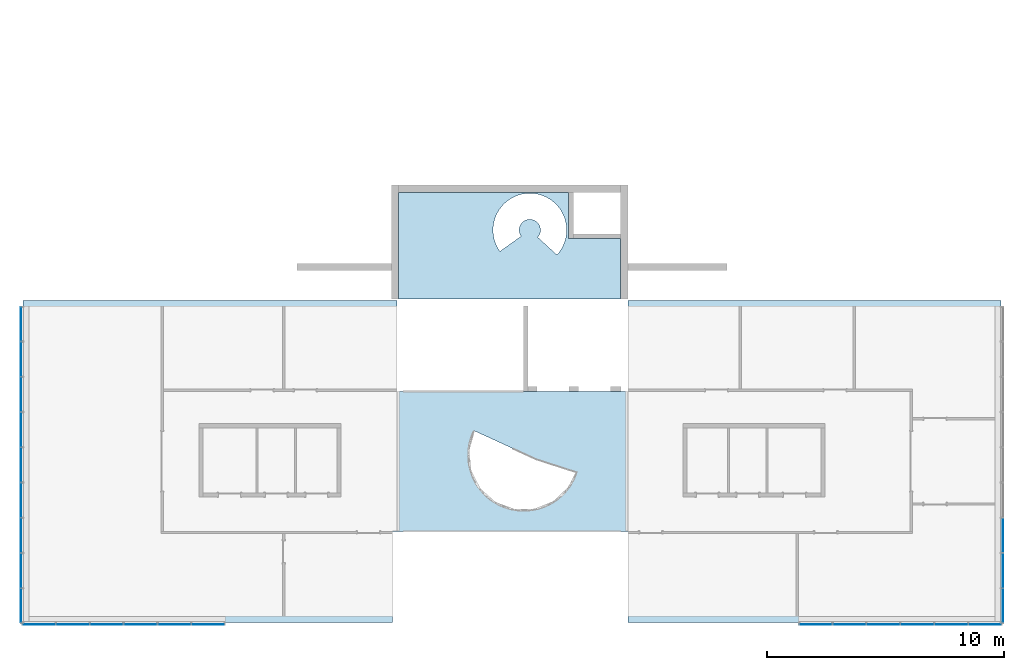
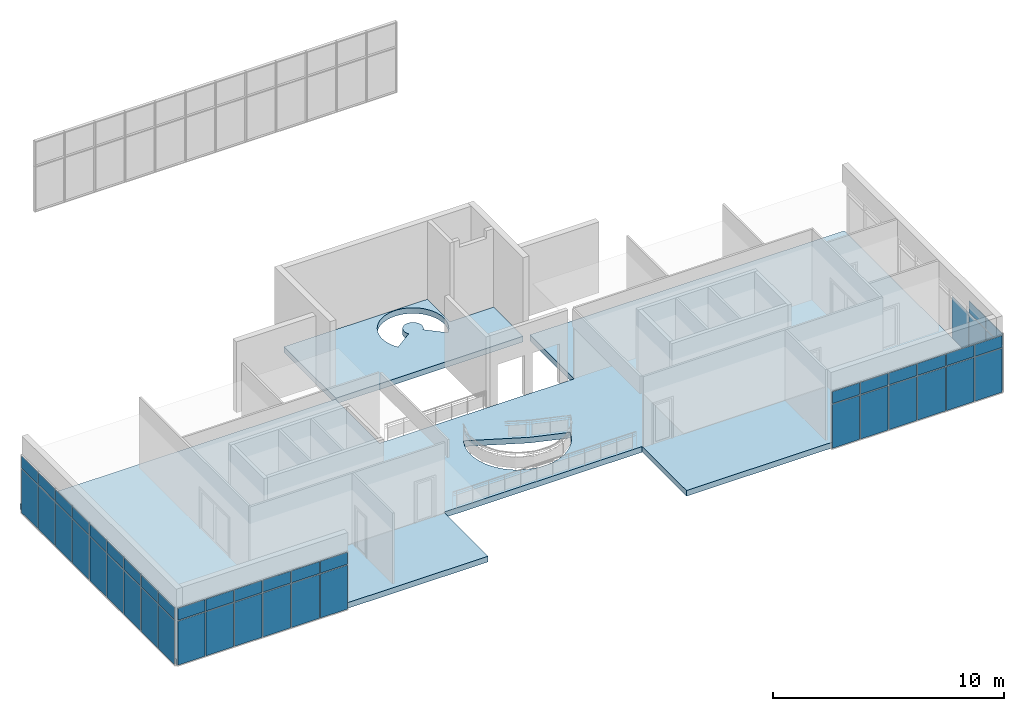
# One storey, part 6 of 11: 47 plates, 2 slabs, 2 openings, 4 elements without a shape of their own.
"""IFC2X3 building model written with IfcOpenShell, lengths in millimetres."""

from ifc_helpers import new_model, entity, si_unit, converted_unit, direction, frame, frame_2d, origin, origin_2d_with_axis, place, context, subcontext, project, spatial, polyline, circle_curve, parameter, trimmed, segment, composite_curve, rectangle, outline, extrude, source, transform, mapped, material, layer, layer_set, layer_usage, type_object, type_shapes, element, aggregate, save


model = new_model("IFC2X3")

# Units and contexts
model_context = context("Model", 3, precision=1e-06, world=origin(), true_north=direction((2.0, 6.12303176911189e-17, 1.0)))
context_of_model = context(None, 3, precision=1e-06, world=origin(), true_north=direction((2.0, 6.12303176911189e-17, 1.0)))
body_context = subcontext(model_context, "Body", "Model", "MODEL_VIEW")
ifc_project = project(units=[si_unit("LENGTHUNIT", "METRE", prefix="MILLI"), si_unit("AREAUNIT", "SQUARE_METRE", prefix="MILLI"), si_unit("VOLUMEUNIT", "CUBIC_METRE", prefix="MILLI"), converted_unit("PLANEANGLEUNIT", "DEGREE", entity("IfcRatioMeasure", 0.0174532925199433), si_unit("PLANEANGLEUNIT", "RADIAN"), dimensions=[0, 0, 0, 0, 0, 0, 0]), si_unit("TIMEUNIT", "SECOND")], contexts=[model_context, context_of_model])

# Site, building, storey
site_placement = place(None, origin())
site = spatial("IfcSite", under=ifc_project, at=site_placement, CompositionType="ELEMENT")
building_placement = place(site_placement, origin())
building = spatial("IfcBuilding", under=site, at=building_placement, CompositionType="ELEMENT")
storey_placement = place(building_placement, frame((0.0, 0.0, 3750.0)))
storey = spatial("IfcBuildingStorey", under=building, at=storey_placement, Name="02. 2 etg.", CompositionType="ELEMENT", Elevation=3750.00000000068)

# Curtain wall, plates
curtain_wall_1_placement = place(storey_placement, origin())
curtain_wall_1 = element("IfcCurtainWall", 1, at=curtain_wall_1_placement, inside=storey, Name="Curtain Wall:Storefront", ObjectType="Curtain Wall:Storefront")
ifc_material_1 = material(Name="Glass")
plate_type_1 = type_object("IfcPlateType", Name="Glazed", PredefinedType="CURTAIN_PANEL")
shared_shape_1 = source(origin(), body_context, "Body", "SweptSolid", [
    extrude(rectangle(XDim=25.0, YDim=1436.66666666667, at=origin_2d_with_axis()), frame((0.0, 37.0, 0.0), z_axis=(0.0, 0.0, 1.0), x_axis=(0.0, 1.0, 0.0)), (0.0, 0.0, 1.0), 2325.0),
])
type_shapes(plate_type_1, [shared_shape_1])
placement = place(building_placement, origin())
plate_1_placement = place(placement, frame((41098.2357123495, -9723.33333333333, 3500.0), z_axis=(0.0, 0.0, 1.0), x_axis=(0.0, -1.0, 0.0)))
plate_1 = element("IfcPlate", 2, at=plate_1_placement, type_object=plate_type_1, material=ifc_material_1, Name="Curtain Wall:Storefront", ObjectType="Glazed", context=body_context, shape_type="MappedRepresentation", body=[
    mapped(shared_shape_1, transform((0.0, 0.0, 0.0), scale=1.0)),
])
plate_2_placement = place(placement, frame((41098.2357123495, -11210.0, 3500.0), z_axis=(0.0, 0.0, 1.0), x_axis=(0.0, -1.0, 0.0)))
plate_2 = element("IfcPlate", 3, at=plate_2_placement, type_object=plate_type_1, material=ifc_material_1, Name="Curtain Wall:Storefront", ObjectType="Glazed", context=body_context, shape_type="MappedRepresentation", body=[
    mapped(shared_shape_1, transform((0.0, 0.0, 0.0), scale=1.0)),
])

curtain_wall_2_placement = place(storey_placement, origin())
curtain_wall_2 = element("IfcCurtainWall", 4, at=curtain_wall_2_placement, inside=storey, Name="Curtain Wall:Storefront", ObjectType="Curtain Wall:Storefront")
plate_type_2 = type_object("IfcPlateType", Name="Glazed", PredefinedType="CURTAIN_PANEL")
shared_shape_2 = source(origin(), body_context, "Body", "SweptSolid", [
    extrude(rectangle(XDim=25.0, YDim=1411.66666666667, at=frame_2d((0.0, 1.13686837721616e-13), x_axis=(1.0, 0.0))), frame((0.0, -37.0, 0.0), z_axis=(0.0, 0.0, 1.0), x_axis=(0.0, 1.0, 0.0)), (0.0, 0.0, 1.0), 2325.0),
])
type_shapes(plate_type_2, [shared_shape_2])
plate_3_placement = place(placement, frame((-240.0, -815.833333333277, 3500.0), z_axis=(0.0, 0.0, 1.0), x_axis=(0.0, -1.0, 0.0)))
plate_3 = element("IfcPlate", 5, at=plate_3_placement, type_object=plate_type_2, material=ifc_material_1, Name="Curtain Wall:Storefront", ObjectType="Glazed", context=body_context, shape_type="MappedRepresentation", body=[
    mapped(shared_shape_2, transform((0.0, 0.0, 0.0), scale=1.0)),
])
plate_4_placement = place(placement, frame((-240.0, -12684.1666666667, 3500.0), z_axis=(0.0, 0.0, 1.0), x_axis=(0.0, -1.0, 0.0)))
plate_4 = element("IfcPlate", 6, at=plate_4_placement, type_object=plate_type_2, material=ifc_material_1, Name="Curtain Wall:Storefront", ObjectType="Glazed", context=body_context, shape_type="MappedRepresentation", body=[
    mapped(shared_shape_2, transform((0.0, 0.0, 0.0), scale=1.0)),
])
plate_type_3 = type_object("IfcPlateType", Name="Glazed", PredefinedType="CURTAIN_PANEL")
shared_shape_3 = source(origin(), body_context, "Body", "SweptSolid", [
    extrude(rectangle(XDim=25.0, YDim=1436.66666666667, at=origin_2d_with_axis()), frame((0.0, -37.0, 0.0), z_axis=(0.0, 0.0, 1.0), x_axis=(0.0, 1.0, 0.0)), (0.0, 0.0, 1.0), 2325.0),
])
type_shapes(plate_type_3, [shared_shape_3])
plate_5_placement = place(placement, frame((-240.0, -2290.0, 3500.0), z_axis=(0.0, 0.0, 1.0), x_axis=(0.0, -1.0, 0.0)))
plate_5 = element("IfcPlate", 7, at=plate_5_placement, type_object=plate_type_3, material=ifc_material_1, Name="Curtain Wall:Storefront", ObjectType="Glazed", context=body_context, shape_type="MappedRepresentation", body=[
    mapped(shared_shape_3, transform((0.0, 0.0, 0.0), scale=1.0)),
])
plate_6_placement = place(placement, frame((-240.0, -3776.66666666662, 3500.0), z_axis=(0.0, 0.0, 1.0), x_axis=(0.0, -1.0, 0.0)))
plate_6 = element("IfcPlate", 8, at=plate_6_placement, type_object=plate_type_3, material=ifc_material_1, Name="Curtain Wall:Storefront", ObjectType="Glazed", context=body_context, shape_type="MappedRepresentation", body=[
    mapped(shared_shape_3, transform((0.0, 0.0, 0.0), scale=1.0)),
])
plate_7_placement = place(placement, frame((-240.0, -5263.3333333333, 3500.0), z_axis=(0.0, 0.0, 1.0), x_axis=(0.0, -1.0, 0.0)))
plate_7 = element("IfcPlate", 9, at=plate_7_placement, type_object=plate_type_3, material=ifc_material_1, Name="Curtain Wall:Storefront", ObjectType="Glazed", context=body_context, shape_type="MappedRepresentation", body=[
    mapped(shared_shape_3, transform((0.0, 0.0, 0.0), scale=1.0)),
])
plate_8_placement = place(placement, frame((-240.0, -6750.0, 3500.0), z_axis=(0.0, 0.0, 1.0), x_axis=(0.0, -1.0, 0.0)))
plate_8 = element("IfcPlate", 10, at=plate_8_placement, type_object=plate_type_3, material=ifc_material_1, Name="Curtain Wall:Storefront", ObjectType="Glazed", context=body_context, shape_type="MappedRepresentation", body=[
    mapped(shared_shape_3, transform((0.0, 0.0, 0.0), scale=1.0)),
])
plate_9_placement = place(placement, frame((-240.0, -8236.66666666664, 3500.0), z_axis=(0.0, 0.0, 1.0), x_axis=(0.0, -1.0, 0.0)))
plate_9 = element("IfcPlate", 11, at=plate_9_placement, type_object=plate_type_3, material=ifc_material_1, Name="Curtain Wall:Storefront", ObjectType="Glazed", context=body_context, shape_type="MappedRepresentation", body=[
    mapped(shared_shape_3, transform((0.0, 0.0, 0.0), scale=1.0)),
])
plate_10_placement = place(placement, frame((-240.0, -9723.33333333331, 3500.0), z_axis=(0.0, 0.0, 1.0), x_axis=(0.0, -1.0, 0.0)))
plate_10 = element("IfcPlate", 12, at=plate_10_placement, type_object=plate_type_3, material=ifc_material_1, Name="Curtain Wall:Storefront", ObjectType="Glazed", context=body_context, shape_type="MappedRepresentation", body=[
    mapped(shared_shape_3, transform((0.0, 0.0, 0.0), scale=1.0)),
])
plate_11_placement = place(placement, frame((-240.0, -11210.0, 3500.0), z_axis=(0.0, 0.0, 1.0), x_axis=(0.0, -1.0, 0.0)))
plate_11 = element("IfcPlate", 13, at=plate_11_placement, type_object=plate_type_3, material=ifc_material_1, Name="Curtain Wall:Storefront", ObjectType="Glazed", context=body_context, shape_type="MappedRepresentation", body=[
    mapped(shared_shape_3, transform((0.0, 0.0, 0.0), scale=1.0)),
])
plate_type_4 = type_object("IfcPlateType", Name="Glazed", PredefinedType="CURTAIN_PANEL")
shared_shape_4 = source(origin(), body_context, "Body", "SweptSolid", [
    extrude(rectangle(XDim=25.0, YDim=1411.66666666667, at=frame_2d((0.0, 5.6843418860808e-14), x_axis=(1.0, 0.0))), frame((0.0, -37.0, 0.0), z_axis=(0.0, 0.0, 1.0), x_axis=(0.0, 1.0, 0.0)), (0.0, 0.0, 1.0), 625.000000000002),
])
type_shapes(plate_type_4, [shared_shape_4])
plate_12_placement = place(storey_placement, frame((-240.0, -815.833333333278, 2125.0), z_axis=(0.0, 0.0, 1.0), x_axis=(0.0, -1.0, 0.0)))
plate_12 = element("IfcPlate", 14, at=plate_12_placement, type_object=plate_type_4, material=ifc_material_1, Name="Curtain Wall:Storefront", ObjectType="Glazed", context=body_context, shape_type="MappedRepresentation", body=[
    mapped(shared_shape_4, transform((0.0, 0.0, 0.0), scale=1.0)),
])
plate_13_placement = place(storey_placement, frame((-240.0, -12684.1666666667, 2125.0), z_axis=(0.0, 0.0, 1.0), x_axis=(0.0, -1.0, 0.0)))
plate_13 = element("IfcPlate", 15, at=plate_13_placement, type_object=plate_type_4, material=ifc_material_1, Name="Curtain Wall:Storefront", ObjectType="Glazed", context=body_context, shape_type="MappedRepresentation", body=[
    mapped(shared_shape_4, transform((0.0, 0.0, 0.0), scale=1.0)),
])
plate_type_5 = type_object("IfcPlateType", Name="Glazed", PredefinedType="CURTAIN_PANEL")
shared_shape_5 = source(origin(), body_context, "Body", "SweptSolid", [
    extrude(rectangle(XDim=25.0, YDim=1436.66666666667, at=origin_2d_with_axis()), frame((0.0, -37.0, 0.0), z_axis=(0.0, 0.0, 1.0), x_axis=(0.0, 1.0, 0.0)), (0.0, 0.0, 1.0), 625.000000000002),
])
type_shapes(plate_type_5, [shared_shape_5])
plate_14_placement = place(storey_placement, frame((-240.0, -2290.0, 2125.0), z_axis=(0.0, 0.0, 1.0), x_axis=(0.0, -1.0, 0.0)))
plate_14 = element("IfcPlate", 16, at=plate_14_placement, type_object=plate_type_5, material=ifc_material_1, Name="Curtain Wall:Storefront", ObjectType="Glazed", context=body_context, shape_type="MappedRepresentation", body=[
    mapped(shared_shape_5, transform((0.0, 0.0, 0.0), scale=1.0)),
])
plate_15_placement = place(storey_placement, frame((-240.0, -3776.66666666662, 2125.0), z_axis=(0.0, 0.0, 1.0), x_axis=(0.0, -1.0, 0.0)))
plate_15 = element("IfcPlate", 17, at=plate_15_placement, type_object=plate_type_5, material=ifc_material_1, Name="Curtain Wall:Storefront", ObjectType="Glazed", context=body_context, shape_type="MappedRepresentation", body=[
    mapped(shared_shape_5, transform((0.0, 0.0, 0.0), scale=1.0)),
])
plate_16_placement = place(storey_placement, frame((-240.0, -5263.3333333333, 2125.0), z_axis=(0.0, 0.0, 1.0), x_axis=(0.0, -1.0, 0.0)))
plate_16 = element("IfcPlate", 18, at=plate_16_placement, type_object=plate_type_5, material=ifc_material_1, Name="Curtain Wall:Storefront", ObjectType="Glazed", context=body_context, shape_type="MappedRepresentation", body=[
    mapped(shared_shape_5, transform((0.0, 0.0, 0.0), scale=1.0)),
])
plate_17_placement = place(storey_placement, frame((-240.0, -6750.0, 2125.0), z_axis=(0.0, 0.0, 1.0), x_axis=(0.0, -1.0, 0.0)))
plate_17 = element("IfcPlate", 19, at=plate_17_placement, type_object=plate_type_5, material=ifc_material_1, Name="Curtain Wall:Storefront", ObjectType="Glazed", context=body_context, shape_type="MappedRepresentation", body=[
    mapped(shared_shape_5, transform((0.0, 0.0, 0.0), scale=1.0)),
])
plate_18_placement = place(storey_placement, frame((-240.0, -8236.66666666664, 2125.0), z_axis=(0.0, 0.0, 1.0), x_axis=(0.0, -1.0, 0.0)))
plate_18 = element("IfcPlate", 20, at=plate_18_placement, type_object=plate_type_5, material=ifc_material_1, Name="Curtain Wall:Storefront", ObjectType="Glazed", context=body_context, shape_type="MappedRepresentation", body=[
    mapped(shared_shape_5, transform((0.0, 0.0, 0.0), scale=1.0)),
])
plate_19_placement = place(storey_placement, frame((-240.0, -9723.33333333331, 2125.0), z_axis=(0.0, 0.0, 1.0), x_axis=(0.0, -1.0, 0.0)))
plate_19 = element("IfcPlate", 21, at=plate_19_placement, type_object=plate_type_5, material=ifc_material_1, Name="Curtain Wall:Storefront", ObjectType="Glazed", context=body_context, shape_type="MappedRepresentation", body=[
    mapped(shared_shape_5, transform((0.0, 0.0, 0.0), scale=1.0)),
])
plate_20_placement = place(storey_placement, frame((-240.0, -11210.0, 2125.0), z_axis=(0.0, 0.0, 1.0), x_axis=(0.0, -1.0, 0.0)))
plate_20 = element("IfcPlate", 22, at=plate_20_placement, type_object=plate_type_5, material=ifc_material_1, Name="Curtain Wall:Storefront", ObjectType="Glazed", context=body_context, shape_type="MappedRepresentation", body=[
    mapped(shared_shape_5, transform((0.0, 0.0, 0.0), scale=1.0)),
])
aggregate(curtain_wall_2, [plate_3, plate_5, plate_6, plate_7, plate_8, plate_9, plate_10, plate_11, plate_4, plate_12, plate_14, plate_15, plate_16, plate_17, plate_18, plate_19, plate_20, plate_13])

curtain_wall_3_placement = place(storey_placement, origin())
curtain_wall_3 = element("IfcCurtainWall", 23, at=curtain_wall_3_placement, inside=storey, Name="Curtain Wall:Storefront", ObjectType="Curtain Wall:Storefront")
plate_type_6 = type_object("IfcPlateType", Name="Glazed", PredefinedType="CURTAIN_PANEL")
shared_shape_6 = source(origin(), body_context, "Body", "SweptSolid", [
    extrude(rectangle(XDim=25.0, YDim=1355.0, at=frame_2d((2.66453525910038e-15, 0.0), x_axis=(1.0, 0.0))), frame((0.0, -37.0, 0.0), z_axis=(0.0, 0.0, 1.0), x_axis=(0.0, 1.0, 0.0)), (0.0, 0.0, 1.0), 2325.0),
])
type_shapes(plate_type_6, [shared_shape_6])
plate_21_placement = place(placement, frame((487.49999999998, -13440.0, 3500.0)))
plate_21 = element("IfcPlate", 24, at=plate_21_placement, type_object=plate_type_6, material=ifc_material_1, Name="Curtain Wall:Storefront", ObjectType="Glazed", context=body_context, shape_type="MappedRepresentation", body=[
    mapped(shared_shape_6, transform((0.0, 0.0, 0.0), scale=1.0)),
])
plate_22_placement = place(placement, frame((7612.5, -13440.0, 3500.0)))
plate_22 = element("IfcPlate", 25, at=plate_22_placement, type_object=plate_type_6, material=ifc_material_1, Name="Curtain Wall:Storefront", ObjectType="Glazed", context=body_context, shape_type="MappedRepresentation", body=[
    mapped(shared_shape_6, transform((0.0, 0.0, 0.0), scale=1.0)),
])
plate_type_7 = type_object("IfcPlateType", Name="Glazed", PredefinedType="CURTAIN_PANEL")
shared_shape_7 = source(origin(), body_context, "Body", "SweptSolid", [
    extrude(rectangle(XDim=25.0, YDim=1380.0, at=frame_2d((2.66453525910038e-15, 0.0), x_axis=(1.0, 0.0))), frame((0.0, -37.0, 0.0), z_axis=(0.0, 0.0, 1.0), x_axis=(0.0, 1.0, 0.0)), (0.0, 0.0, 1.0), 2325.0),
])
type_shapes(plate_type_7, [shared_shape_7])
plate_23_placement = place(placement, frame((1905.0, -13440.0, 3500.0)))
plate_23 = element("IfcPlate", 26, at=plate_23_placement, type_object=plate_type_7, material=ifc_material_1, Name="Curtain Wall:Storefront", ObjectType="Glazed", context=body_context, shape_type="MappedRepresentation", body=[
    mapped(shared_shape_7, transform((0.0, 0.0, 0.0), scale=1.0)),
])
plate_24_placement = place(placement, frame((3335.0, -13440.0, 3500.0)))
plate_24 = element("IfcPlate", 27, at=plate_24_placement, type_object=plate_type_7, material=ifc_material_1, Name="Curtain Wall:Storefront", ObjectType="Glazed", context=body_context, shape_type="MappedRepresentation", body=[
    mapped(shared_shape_7, transform((0.0, 0.0, 0.0), scale=1.0)),
])
plate_25_placement = place(placement, frame((4765.0, -13440.0, 3500.0)))
plate_25 = element("IfcPlate", 28, at=plate_25_placement, type_object=plate_type_7, material=ifc_material_1, Name="Curtain Wall:Storefront", ObjectType="Glazed", context=body_context, shape_type="MappedRepresentation", body=[
    mapped(shared_shape_7, transform((0.0, 0.0, 0.0), scale=1.0)),
])
plate_26_placement = place(placement, frame((6195.0, -13440.0, 3500.0)))
plate_26 = element("IfcPlate", 29, at=plate_26_placement, type_object=plate_type_7, material=ifc_material_1, Name="Curtain Wall:Storefront", ObjectType="Glazed", context=body_context, shape_type="MappedRepresentation", body=[
    mapped(shared_shape_7, transform((0.0, 0.0, 0.0), scale=1.0)),
])
plate_type_8 = type_object("IfcPlateType", Name="Glazed", PredefinedType="CURTAIN_PANEL")
shared_shape_8 = source(origin(), body_context, "Body", "SweptSolid", [
    extrude(rectangle(XDim=25.0, YDim=1355.0, at=frame_2d((1.77635683940025e-15, 5.6843418860808e-14), x_axis=(1.0, 0.0))), frame((0.0, -37.0, 0.0), z_axis=(0.0, 0.0, 1.0), x_axis=(0.0, 1.0, 0.0)), (0.0, 0.0, 1.0), 625.000000000002),
])
type_shapes(plate_type_8, [shared_shape_8])
plate_27_placement = place(storey_placement, frame((487.49999999998, -13440.0, 2125.0)))
plate_27 = element("IfcPlate", 30, at=plate_27_placement, type_object=plate_type_8, material=ifc_material_1, Name="Curtain Wall:Storefront", ObjectType="Glazed", context=body_context, shape_type="MappedRepresentation", body=[
    mapped(shared_shape_8, transform((0.0, 0.0, 0.0), scale=1.0)),
])
plate_28_placement = place(storey_placement, frame((7612.5, -13440.0, 2125.0)))
plate_28 = element("IfcPlate", 31, at=plate_28_placement, type_object=plate_type_8, material=ifc_material_1, Name="Curtain Wall:Storefront", ObjectType="Glazed", context=body_context, shape_type="MappedRepresentation", body=[
    mapped(shared_shape_8, transform((0.0, 0.0, 0.0), scale=1.0)),
])
plate_type_9 = type_object("IfcPlateType", Name="Glazed", PredefinedType="CURTAIN_PANEL")
shared_shape_9 = source(origin(), body_context, "Body", "SweptSolid", [
    extrude(rectangle(XDim=25.0, YDim=1380.0, at=frame_2d((2.66453525910038e-15, 0.0), x_axis=(1.0, 0.0))), frame((0.0, -37.0, 0.0), z_axis=(0.0, 0.0, 1.0), x_axis=(0.0, 1.0, 0.0)), (0.0, 0.0, 1.0), 625.000000000002),
])
type_shapes(plate_type_9, [shared_shape_9])
plate_29_placement = place(storey_placement, frame((1905.0, -13440.0, 2125.0)))
plate_29 = element("IfcPlate", 32, at=plate_29_placement, type_object=plate_type_9, material=ifc_material_1, Name="Curtain Wall:Storefront", ObjectType="Glazed", context=body_context, shape_type="MappedRepresentation", body=[
    mapped(shared_shape_9, transform((0.0, 0.0, 0.0), scale=1.0)),
])
plate_30_placement = place(storey_placement, frame((3335.0, -13440.0, 2125.0)))
plate_30 = element("IfcPlate", 33, at=plate_30_placement, type_object=plate_type_9, material=ifc_material_1, Name="Curtain Wall:Storefront", ObjectType="Glazed", context=body_context, shape_type="MappedRepresentation", body=[
    mapped(shared_shape_9, transform((0.0, 0.0, 0.0), scale=1.0)),
])
plate_31_placement = place(storey_placement, frame((4765.0, -13440.0, 2125.0)))
plate_31 = element("IfcPlate", 34, at=plate_31_placement, type_object=plate_type_9, material=ifc_material_1, Name="Curtain Wall:Storefront", ObjectType="Glazed", context=body_context, shape_type="MappedRepresentation", body=[
    mapped(shared_shape_9, transform((0.0, 0.0, 0.0), scale=1.0)),
])
plate_32_placement = place(storey_placement, frame((6195.0, -13440.0, 2125.0)))
plate_32 = element("IfcPlate", 35, at=plate_32_placement, type_object=plate_type_9, material=ifc_material_1, Name="Curtain Wall:Storefront", ObjectType="Glazed", context=body_context, shape_type="MappedRepresentation", body=[
    mapped(shared_shape_9, transform((0.0, 0.0, 0.0), scale=1.0)),
])
aggregate(curtain_wall_3, [plate_21, plate_23, plate_24, plate_25, plate_26, plate_22, plate_27, plate_29, plate_30, plate_31, plate_32, plate_28])

# Plate
plate_type_10 = type_object("IfcPlateType", Name="Glazed", PredefinedType="CURTAIN_PANEL")
shared_shape_10 = source(origin(), body_context, "Body", "SweptSolid", [
    extrude(rectangle(XDim=25.0, YDim=1411.66666666667, at=origin_2d_with_axis()), frame((0.0, 37.0, 0.0), z_axis=(0.0, 0.0, 1.0), x_axis=(0.0, 1.0, 0.0)), (0.0, 0.0, 1.0), 2325.0),
])
type_shapes(plate_type_10, [shared_shape_10])
plate_33_placement = place(placement, frame((41098.2357123495, -12684.1666666667, 3500.0), z_axis=(0.0, 0.0, 1.0), x_axis=(0.0, -1.0, 0.0)))
plate_33 = element("IfcPlate", 36, at=plate_33_placement, type_object=plate_type_10, material=ifc_material_1, Name="Curtain Wall:Storefront", ObjectType="Glazed", context=body_context, shape_type="MappedRepresentation", body=[
    mapped(shared_shape_10, transform((0.0, 0.0, 0.0), scale=1.0)),
])

plate_type_11 = type_object("IfcPlateType", Name="Glazed", PredefinedType="CURTAIN_PANEL")
shared_shape_11 = source(origin(), body_context, "Body", "SweptSolid", [
    extrude(rectangle(XDim=25.0, YDim=1411.66666666667, at=origin_2d_with_axis()), frame((0.0, 37.0, 0.0), z_axis=(0.0, 0.0, 1.0), x_axis=(0.0, 1.0, 0.0)), (0.0, 0.0, 1.0), 625.000000000002),
])
type_shapes(plate_type_11, [shared_shape_11])
plate_34_placement = place(storey_placement, frame((41098.2357123495, -12684.1666666667, 2125.0), z_axis=(0.0, 0.0, 1.0), x_axis=(0.0, -1.0, 0.0)))
plate_34 = element("IfcPlate", 37, at=plate_34_placement, type_object=plate_type_11, material=ifc_material_1, Name="Curtain Wall:Storefront", ObjectType="Glazed", context=body_context, shape_type="MappedRepresentation", body=[
    mapped(shared_shape_11, transform((0.0, 0.0, 0.0), scale=1.0)),
])

plate_type_12 = type_object("IfcPlateType", Name="Glazed", PredefinedType="CURTAIN_PANEL")
shared_shape_12 = source(origin(), body_context, "Body", "SweptSolid", [
    extrude(rectangle(XDim=25.0, YDim=1436.66666666667, at=origin_2d_with_axis()), frame((0.0, 37.0, 0.0), z_axis=(0.0, 0.0, 1.0), x_axis=(0.0, 1.0, 0.0)), (0.0, 0.0, 1.0), 625.000000000002),
])
type_shapes(plate_type_12, [shared_shape_12])
plate_35_placement = place(storey_placement, frame((41098.2357123495, -11210.0, 2125.0), z_axis=(0.0, 0.0, 1.0), x_axis=(0.0, -1.0, 0.0)))
plate_35 = element("IfcPlate", 38, at=plate_35_placement, type_object=plate_type_12, material=ifc_material_1, Name="Curtain Wall:Storefront", ObjectType="Glazed", context=body_context, shape_type="MappedRepresentation", body=[
    mapped(shared_shape_12, transform((0.0, 0.0, 0.0), scale=1.0)),
])

aggregate(curtain_wall_1, [plate_1, plate_2, plate_33, plate_35, plate_34])

# Curtain wall, plates
curtain_wall_4_placement = place(storey_placement, origin())
curtain_wall_4 = element("IfcCurtainWall", 39, at=curtain_wall_4_placement, inside=storey, Name="Curtain Wall:Storefront", ObjectType="Curtain Wall:Storefront")
plate_type_13 = type_object("IfcPlateType", Name="Glazed", PredefinedType="CURTAIN_PANEL")
shared_shape_13 = source(origin(), body_context, "Body", "SweptSolid", [
    extrude(rectangle(XDim=25.0, YDim=1356.66666666667, at=origin_2d_with_axis()), frame((0.0, 37.0, 0.0), z_axis=(0.0, 0.0, 1.0), x_axis=(0.0, 1.0, 0.0)), (0.0, 0.0, 1.0), 2325.0),
])
type_shapes(plate_type_13, [shared_shape_13])
plate_36_placement = place(placement, frame((40369.9023790162, -13440.0, 3500.0), z_axis=(0.0, 0.0, 1.0), x_axis=(-1.0, 0.0, 0.0)))
plate_36 = element("IfcPlate", 40, at=plate_36_placement, type_object=plate_type_13, material=ifc_material_1, Name="Curtain Wall:Storefront", ObjectType="Glazed", context=body_context, shape_type="MappedRepresentation", body=[
    mapped(shared_shape_13, transform((0.0, 0.0, 0.0), scale=1.0)),
])
plate_37_placement = place(placement, frame((33236.5690456828, -13440.0, 3500.0), z_axis=(0.0, 0.0, 1.0), x_axis=(-1.0, 0.0, 0.0)))
plate_37 = element("IfcPlate", 41, at=plate_37_placement, type_object=plate_type_13, material=ifc_material_1, Name="Curtain Wall:Storefront", ObjectType="Glazed", context=body_context, shape_type="MappedRepresentation", body=[
    mapped(shared_shape_13, transform((0.0, 0.0, 0.0), scale=1.0)),
])
plate_type_14 = type_object("IfcPlateType", Name="Glazed", PredefinedType="CURTAIN_PANEL")
shared_shape_14 = source(origin(), body_context, "Body", "SweptSolid", [
    extrude(rectangle(XDim=25.0, YDim=1381.66666666667, at=origin_2d_with_axis()), frame((0.0, 37.0, 0.0), z_axis=(0.0, 0.0, 1.0), x_axis=(0.0, 1.0, 0.0)), (0.0, 0.0, 1.0), 2325.0),
])
type_shapes(plate_type_14, [shared_shape_14])
plate_38_placement = place(placement, frame((38950.7357123495, -13440.0, 3500.0), z_axis=(0.0, 0.0, 1.0), x_axis=(-1.0, 0.0, 0.0)))
plate_38 = element("IfcPlate", 42, at=plate_38_placement, type_object=plate_type_14, material=ifc_material_1, Name="Curtain Wall:Storefront", ObjectType="Glazed", context=body_context, shape_type="MappedRepresentation", body=[
    mapped(shared_shape_14, transform((0.0, 0.0, 0.0), scale=1.0)),
])
plate_39_placement = place(placement, frame((37519.0690456828, -13440.0, 3500.0), z_axis=(0.0, 0.0, 1.0), x_axis=(-1.0, 0.0, 0.0)))
plate_39 = element("IfcPlate", 43, at=plate_39_placement, type_object=plate_type_14, material=ifc_material_1, Name="Curtain Wall:Storefront", ObjectType="Glazed", context=body_context, shape_type="MappedRepresentation", body=[
    mapped(shared_shape_14, transform((0.0, 0.0, 0.0), scale=1.0)),
])
plate_40_placement = place(placement, frame((36087.4023790161, -13440.0, 3500.0), z_axis=(0.0, 0.0, 1.0), x_axis=(-1.0, 0.0, 0.0)))
plate_40 = element("IfcPlate", 44, at=plate_40_placement, type_object=plate_type_14, material=ifc_material_1, Name="Curtain Wall:Storefront", ObjectType="Glazed", context=body_context, shape_type="MappedRepresentation", body=[
    mapped(shared_shape_14, transform((0.0, 0.0, 0.0), scale=1.0)),
])
plate_41_placement = place(placement, frame((34655.7357123495, -13440.0, 3500.0), z_axis=(0.0, 0.0, 1.0), x_axis=(-1.0, 0.0, 0.0)))
plate_41 = element("IfcPlate", 45, at=plate_41_placement, type_object=plate_type_14, material=ifc_material_1, Name="Curtain Wall:Storefront", ObjectType="Glazed", context=body_context, shape_type="MappedRepresentation", body=[
    mapped(shared_shape_14, transform((0.0, 0.0, 0.0), scale=1.0)),
])
plate_type_15 = type_object("IfcPlateType", Name="Glazed", PredefinedType="CURTAIN_PANEL")
shared_shape_15 = source(origin(), body_context, "Body", "SweptSolid", [
    extrude(rectangle(XDim=25.0, YDim=1356.66666666667, at=origin_2d_with_axis()), frame((0.0, 37.0, 0.0), z_axis=(0.0, 0.0, 1.0), x_axis=(0.0, 1.0, 0.0)), (0.0, 0.0, 1.0), 625.000000000002),
])
type_shapes(plate_type_15, [shared_shape_15])
plate_42_placement = place(storey_placement, frame((40369.9023790162, -13440.0, 2125.0), z_axis=(0.0, 0.0, 1.0), x_axis=(-1.0, 0.0, 0.0)))
plate_42 = element("IfcPlate", 46, at=plate_42_placement, type_object=plate_type_15, material=ifc_material_1, Name="Curtain Wall:Storefront", ObjectType="Glazed", context=body_context, shape_type="MappedRepresentation", body=[
    mapped(shared_shape_15, transform((0.0, 0.0, 0.0), scale=1.0)),
])
plate_43_placement = place(storey_placement, frame((33236.5690456828, -13440.0, 2125.0), z_axis=(0.0, 0.0, 1.0), x_axis=(-1.0, 0.0, 0.0)))
plate_43 = element("IfcPlate", 47, at=plate_43_placement, type_object=plate_type_15, material=ifc_material_1, Name="Curtain Wall:Storefront", ObjectType="Glazed", context=body_context, shape_type="MappedRepresentation", body=[
    mapped(shared_shape_15, transform((0.0, 0.0, 0.0), scale=1.0)),
])
plate_type_16 = type_object("IfcPlateType", Name="Glazed", PredefinedType="CURTAIN_PANEL")
shared_shape_16 = source(origin(), body_context, "Body", "SweptSolid", [
    extrude(rectangle(XDim=25.0, YDim=1381.66666666667, at=origin_2d_with_axis()), frame((0.0, 37.0, 0.0), z_axis=(0.0, 0.0, 1.0), x_axis=(0.0, 1.0, 0.0)), (0.0, 0.0, 1.0), 625.000000000002),
])
type_shapes(plate_type_16, [shared_shape_16])
plate_44_placement = place(storey_placement, frame((38950.7357123495, -13440.0, 2125.0), z_axis=(0.0, 0.0, 1.0), x_axis=(-1.0, 0.0, 0.0)))
plate_44 = element("IfcPlate", 48, at=plate_44_placement, type_object=plate_type_16, material=ifc_material_1, Name="Curtain Wall:Storefront", ObjectType="Glazed", context=body_context, shape_type="MappedRepresentation", body=[
    mapped(shared_shape_16, transform((0.0, 0.0, 0.0), scale=1.0)),
])
plate_45_placement = place(storey_placement, frame((37519.0690456828, -13440.0, 2125.0), z_axis=(0.0, 0.0, 1.0), x_axis=(-1.0, 0.0, 0.0)))
plate_45 = element("IfcPlate", 49, at=plate_45_placement, type_object=plate_type_16, material=ifc_material_1, Name="Curtain Wall:Storefront", ObjectType="Glazed", context=body_context, shape_type="MappedRepresentation", body=[
    mapped(shared_shape_16, transform((0.0, 0.0, 0.0), scale=1.0)),
])
plate_46_placement = place(storey_placement, frame((36087.4023790161, -13440.0, 2125.0), z_axis=(0.0, 0.0, 1.0), x_axis=(-1.0, 0.0, 0.0)))
plate_46 = element("IfcPlate", 50, at=plate_46_placement, type_object=plate_type_16, material=ifc_material_1, Name="Curtain Wall:Storefront", ObjectType="Glazed", context=body_context, shape_type="MappedRepresentation", body=[
    mapped(shared_shape_16, transform((0.0, 0.0, 0.0), scale=1.0)),
])
plate_47_placement = place(storey_placement, frame((34655.7357123495, -13440.0, 2125.0), z_axis=(0.0, 0.0, 1.0), x_axis=(-1.0, 0.0, 0.0)))
plate_47 = element("IfcPlate", 51, at=plate_47_placement, type_object=plate_type_16, material=ifc_material_1, Name="Curtain Wall:Storefront", ObjectType="Glazed", context=body_context, shape_type="MappedRepresentation", body=[
    mapped(shared_shape_16, transform((0.0, 0.0, 0.0), scale=1.0)),
])
aggregate(curtain_wall_4, [plate_36, plate_38, plate_39, plate_40, plate_41, plate_37, plate_42, plate_44, plate_45, plate_46, plate_47, plate_43])

# Slab, opening
ifc_material_2 = material(Name="Default Floor")
ifc_layer = layer(ifc_material_2, 300.0)
ifc_layer_set = layer_set([ifc_layer], Name="Floor:Generic 300mm")
ifc_layer_usage_1 = layer_usage(ifc_layer_set, "AXIS3", "POSITIVE", 0.0)
slab_1_placement = place(storey_placement, frame((-190.0, -13390.0, -300.0)))
slab_1 = element("IfcSlab", 52, at=slab_1_placement, inside=storey, material=ifc_layer_usage_1, Name="Floor:Generic 300mm", ObjectType="Floor:Generic 300mm", PredefinedType="FLOOR", context=body_context, shape_type="SweptSolid", body=[
    extrude(outline(polyline([(4839.11785617474, 6790.0), (4839.11785617474, 2950.0), (-4889.11785617472, 2950.0), (-4889.1178561747, 6790.0), (-20619.1178561747, 6790.0), (-20619.1178561747, -6790.0), (-4889.1178561747, -6790.0), (-4889.11785617471, -2950.0), (5035.11785617473, -2950.0), (5035.11785617473, -6790.0), (20619.1178561747, -6790.0), (20619.1178561747, 6790.0), (4839.11785617474, 6790.0)])), frame((20619.1178561747, 6790.0, 300.0), z_axis=(0.0, 0.0, -1.0), x_axis=(-1.0, 0.0, 0.0)), (0.0, 0.0, 1.0), 300.0),
])
opening_1_placement = place(slab_1_placement, frame((21330.1159272963, 7095.72050506224, 300.0)))
element("IfcOpeningElement", 53, at=opening_1_placement, cuts=slab_1, Name="Floor:Generic 300mm:2", ObjectType="Opening", context=body_context, shape_type="SweptSolid", body=[
    extrude(outline(composite_curve([segment(trimmed(circle_curve(frame_2d((-176.974275599361, -134.614409091592), x_axis=(0.90890512795886, 0.417002959657111)), 2344.10124724748), [parameter(153.777959889841)], [parameter(342.08827731092)], True, "PARAMETER"), True, "CONTINUOUS"), segment(polyline([(2150.95657392558, 140.24667796379), (369.231639670756, -70.1233389818927)]), True, "CONTINUOUS"), segment(polyline([(369.231639670755, -70.1233389818918), (-2520.18821359633, -70.1233389818972)]), True, "CONTINUOUS")], self_intersect=False)), frame((0.0, 0.0, 0.0), z_axis=(0.0, 0.0, 1.0), x_axis=(0.908905127963297, -0.417002959656191, 0.0)), (0.0, 0.0, -1.0), 300.0),
])

ifc_layer_usage_2 = layer_usage(ifc_layer_set, "AXIS3", "POSITIVE", 0.0)
slab_2_placement = place(storey_placement, frame((15644.0, 240.0, -300.0)))
slab_2 = element("IfcSlab", 54, at=slab_2_placement, inside=storey, material=ifc_layer_usage_2, Name="Floor:Generic 300mm", ObjectType="Floor:Generic 300mm", PredefinedType="FLOOR", context=body_context, shape_type="SweptSolid", body=[
    extrude(outline(polyline([(-2484.94831356608, 2250.0), (-2484.94831356607, 300.0), (-4684.94831356608, 300.0), (-4684.94831356608, -2250.0), (4684.94831356608, -2250.0), (4684.94831356607, 2250.0), (-2484.94831356608, 2250.0)])), frame((4684.94831356608, 2250.0, 300.0), z_axis=(0.0, 0.0, -1.0), x_axis=(-1.0, 0.0, 0.0)), (0.0, 0.0, 1.0), 300.0),
])
opening_2_placement = place(slab_2_placement, frame((5498.30097253062, 2281.09996766389, 300.0)))
element("IfcOpeningElement", 55, at=opening_2_placement, cuts=slab_2, Name="Floor:Generic 300mm:2", ObjectType="Opening", context=body_context, shape_type="SweptSolid", body=[
    extrude(outline(composite_curve([segment(trimmed(circle_curve(frame_2d((38.4076130815811, -626.998369648573), x_axis=(1.0, 0.0)), 1550.0), [parameter(144.589844690847)], [parameter(42.4208524997169)], True, "PARAMETER"), True, "CONTINUOUS"), segment(polyline([(1182.63293156519, 418.586835172667), (370.602060383279, -323.441374700476)]), True, "CONTINUOUS"), segment(trimmed(circle_curve(frame_2d((38.4076130815811, -626.998369648573), x_axis=(1.0, 0.0)), 449.999999999998), [parameter(144.589844690852)], [parameter(42.4208524997168)], True, "PARAMETER"), False, "CONTINUOUS"), segment(polyline([(-328.353685993554, -366.256831912983), (-1224.88130595492, 271.11137144078)]), True, "CONTINUOUS")], self_intersect=False)), frame((0.0, 0.0, 0.0), z_axis=(0.0, 0.0, -1.0), x_axis=(1.0, 0.0, 0.0)), (0.0, 0.0, 1.0), 300.0),
])

save(model, "model.ifc")
